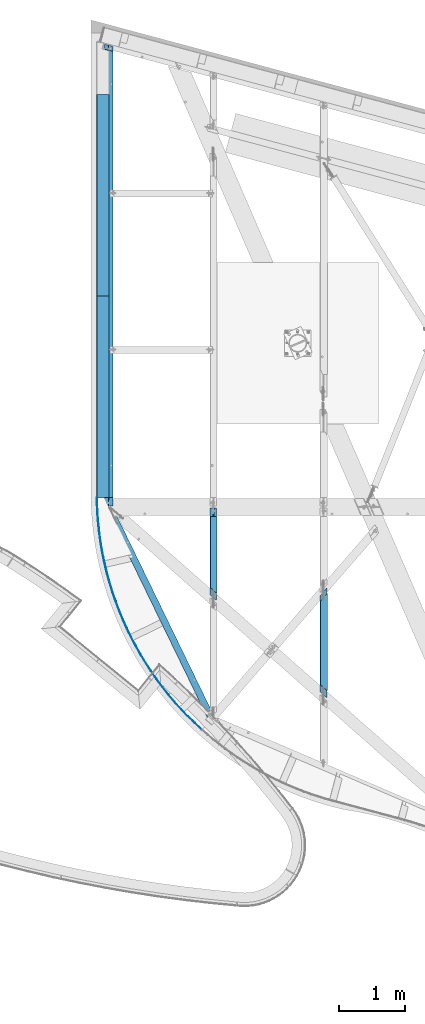
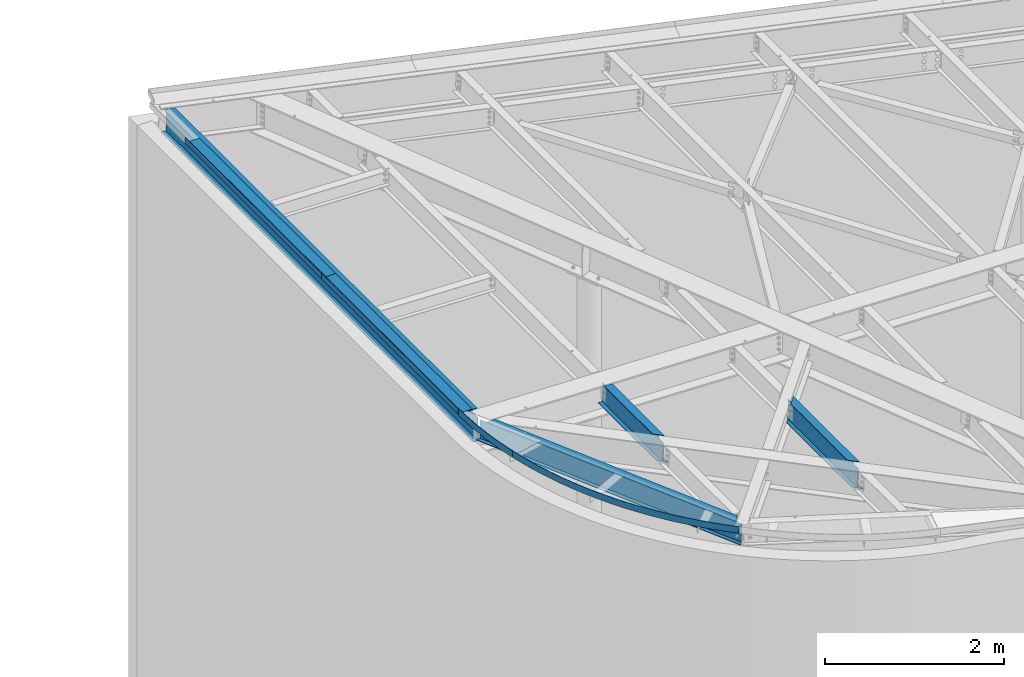
# One storey, part 1153 of 1763: 8 beams, 4 elements without a shape of their own.
"""IFC2X3 building model written with IfcOpenShell, lengths in millimetres."""

from ifc_helpers import new_model, si_unit, frame, origin_with_axes, place, context, subcontext, project, spatial, faceted_brep, material, type_object, element, aggregate, save


model = new_model("IFC2X3")

# Units and contexts
model_context = context("Model", 3, precision=1e-05, world=origin_with_axes())
body_context = subcontext(model_context, "Body", "Model", "MODEL_VIEW")
ifc_project = project(units=[si_unit("LENGTHUNIT", "METRE", prefix="MILLI"), si_unit("AREAUNIT", "SQUARE_METRE"), si_unit("VOLUMEUNIT", "CUBIC_METRE"), si_unit("MASSUNIT", "GRAM", prefix="KILO"), si_unit("TIMEUNIT", "SECOND"), si_unit("PLANEANGLEUNIT", "RADIAN"), si_unit("SOLIDANGLEUNIT", "STERADIAN"), si_unit("THERMODYNAMICTEMPERATUREUNIT", "DEGREE_CELSIUS"), si_unit("LUMINOUSINTENSITYUNIT", "LUMEN")], contexts=[model_context])

# Site, building, storey
site_placement = place(None, origin_with_axes())
site = spatial("IfcSite", under=ifc_project, at=site_placement, CompositionType="ELEMENT")
building_placement = place(site_placement, origin_with_axes())
building = spatial("IfcBuilding", under=site, at=building_placement, Name="Undefined", CompositionType="ELEMENT")
storey_placement = place(building_placement, origin_with_axes())
storey = spatial("IfcBuildingStorey", under=building, at=storey_placement, Name="Undefined", CompositionType="ELEMENT", Elevation=0.0)

# Assembly, beams
assembly_1_placement = place(storey_placement, origin_with_axes())
assembly_1 = element("IfcElementAssembly", 1, at=assembly_1_placement, inside=storey, Name="BEAM", AssemblyPlace="NOTDEFINED", PredefinedType="RIGID_FRAME")
ifc_material_1 = material(Name="STEEL/A36")
beam_type_1 = type_object("IfcBeamType", PredefinedType="NOTDEFINED")
beam_1_placement = place(assembly_1_placement, frame((-49591.1354609503, 64870.8062499989, 12741.275), z_axis=(0.0, -1.0, 0.0), x_axis=(-1.0, 0.0, 0.0)))
beam_1 = element("IfcBeam", 2, at=beam_1_placement, type_object=beam_type_1, material=ifc_material_1, Name="BENT_PLATE", context=body_context, shape_type="Brep", body=[
    faceted_brep([(0.0, -3.17499999999927, -1523.99999999999), (0.0, -3.17499999999927, 1524.0), (0.0, 3.17499999999927, 1524.0), (0.0, 3.17499999999927, -1523.99999999999), (184.149993896484, 3.17499999999927, 1524.0), (184.149993896484, 3.17499999999927, -1523.99999999999), (177.799993896479, -3.17499999999927, -1523.99999999999), (177.799993896479, -3.17499999999927, 1524.0), (184.149993896484, -73.0249969482429, 1524.0), (184.149993896484, -73.0249969482429, -1523.99999999999), (177.799993896479, -73.0249969482429, 1524.0), (177.799993896479, -73.0249969482429, -1523.99999999999)], [[[0, 1, 2, 3]], [[3, 2, 4, 5]], [[1, 0, 6, 7]], [[5, 4, 8, 9]], [[4, 2, 1, 7, 10, 8]], [[7, 6, 11, 10]], [[6, 0, 3, 5, 9, 11]], [[10, 11, 9, 8]]]),
])
beam_2_placement = place(assembly_1_placement, frame((-49591.1354609503, 67918.8062499989, 12741.275), z_axis=(0.0, -1.0, 0.0), x_axis=(-1.0, 0.0, 0.0)))
beam_2 = element("IfcBeam", 3, at=beam_2_placement, type_object=beam_type_1, material=ifc_material_1, Name="BENT_PLATE", context=body_context, shape_type="Brep", body=[
    faceted_brep([(0.0, -3.17499999999927, -1523.99999999999), (0.0, -3.17499999999927, 1524.0), (0.0, 3.17499999999927, 1524.0), (0.0, 3.17499999999927, -1523.99999999999), (184.149993896484, 3.17499999999927, 1524.0), (184.149993896484, 3.17499999999927, -1523.99999999999), (177.799993896479, -3.17499999999927, -1523.99999999999), (177.799993896479, -3.17499999999927, 1524.0), (184.149993896484, -73.0249969482429, 1524.0), (184.149993896484, -73.0249969482429, -1523.99999999999), (177.799993896479, -73.0249969482429, 1524.0), (177.799993896479, -73.0249969482429, -1523.99999999999)], [[[0, 1, 2, 3]], [[3, 2, 4, 5]], [[1, 0, 6, 7]], [[5, 4, 8, 9]], [[4, 2, 1, 7, 10, 8]], [[7, 6, 11, 10]], [[6, 0, 3, 5, 9, 11]], [[10, 11, 9, 8]]]),
])

assembly_2_placement = place(storey_placement, origin_with_axes())
assembly_2 = element("IfcElementAssembly", 4, at=assembly_2_placement, inside=storey, Name="BEAM", AssemblyPlace="NOTDEFINED", PredefinedType="RIGID_FRAME")
beam_type_2 = type_object("IfcBeamType", PredefinedType="NOTDEFINED")
beam_3_placement = place(assembly_2_placement, frame((-49650.8171570623, 62338.1625967416, 12762.537573956), z_axis=(0.00108272801955172, -0.00914849716521712, 0.999957565449481), x_axis=(-0.117525099963492, 0.993027181691531, 0.00921234499713815)))
beam_3 = element("IfcBeam", 5, at=beam_3_placement, type_object=beam_type_2, material=ifc_material_1, Name="PLATE", context=body_context, shape_type="Brep", body=[
    faceted_brep([(-0.333695476205321, 3.15741545087076, -44.4499999999898), (-0.33369547604525, 3.157415450798, 44.4499999999844), (50.144475592213, 8.22368790923792, 44.4500000000044), (50.144475592082, 8.22368790933251, -44.4499999999698), (0.333695476190769, -3.15741545087803, 44.449999999988), (0.33369547604525, -3.157415450798, -44.4499999999862), (50.7453385115368, 1.90217988102813, -44.4499999999643), (50.7453385116678, 1.9021798809481, 44.4500000000098), (100.673192931077, 12.7581774184728, 44.4500000000298), (100.673192930946, 12.7581774185601, -44.449999999948), (101.20746119984, 6.43069313042361, -44.4499999999425), (101.207461199971, 6.43069313034357, 44.4500000000317), (151.246854412151, 16.7603812387897, 44.4500000000517), (151.246854412006, 16.7603812388697, -44.4499999999261), (151.714468795893, 10.4276222202679, -44.4499999999189), (151.714468796039, 10.4276222201734, 44.4500000000571), (201.859852924026, 20.2298556450842, 44.4500000000753), (201.859852923895, 20.2298556451715, -44.4499999999025), (202.260761578305, 13.8925240102762, -44.4499999998952), (202.260761578436, 13.8925240102035, 44.4500000000789), (252.50657699407, 23.1662159760963, 44.4500000000971), (252.506576993939, 23.166215976169, -44.449999999877), (252.840735470032, 16.8250143461482, -44.4499999998734), (252.840735470163, 16.8250143460682, 44.4500000001044), (303.181411410435, 25.5691366769752, 44.4500000001226), (303.181411410289, 25.5691366770552, -44.4499999998552), (303.448782659863, 19.2247681021254, -44.4499999998498), (303.448782659994, 19.2247681020381, 44.4500000001262), (353.878737844672, 27.4383513354842, 44.4500000001462), (353.878737844527, 27.4383513355642, -44.4499999998297), (354.07929222408, 21.0915192170432, -44.4499999998261), (354.079292224225, 21.0915192169632, 44.4500000001517), (404.592935474662, 28.7736527114175, 44.4500000001699), (404.592935474517, 28.7736527114903, -44.4499999998043), (404.726650748547, 22.4250607238719, -44.4499999998006), (404.726650748693, 22.4250607237918, 44.4500000001735), (455.31838160778, 29.5748927596578, 44.4500000001954), (455.318381607634, 29.5748927597378, -44.4499999997788), (455.385242951117, 23.2252447726059, -44.4499999997752), (455.385242951263, 23.2252447725259, 44.450000000199), (506.049452304258, 29.8419826465906, 44.4500000002208), (506.049452304112, 29.8419826466707, -44.4499999997552), (506.049452304112, 23.4919826466794, -44.4499999997497), (506.049452304243, 23.4919826465994, 44.4500000002245), (556.780523000736, 29.5748927598906, 44.4500000002463), (556.780523000605, 29.5748927599707, -44.4499999997297), (556.713661657093, 23.2252447728315, -44.4499999997261), (556.713661657224, 23.2252447727515, 44.4500000002517), (607.505969133854, 28.7736527118759, 44.4500000002718), (607.505969133708, 28.7736527119559, -44.4499999997024), (607.372253859648, 22.4250607243303, -44.4499999996988), (607.372253859794, 22.4250607242502, 44.4500000002754), (658.220166763829, 27.4383513361827, 44.450000000299), (658.220166763698, 27.4383513362627, -44.4499999996769), (658.019612384116, 21.0915192177345, -44.4499999996715), (658.019612384262, 21.0915192176617, 44.4500000003027), (708.917493198082, 25.5691366779065, 44.4500000003263), (708.917493197936, 25.5691366779938, -44.4499999996515), (708.650121948333, 19.2247681030494, -44.4499999996442), (708.650121948478, 19.2247681029621, 44.45000000033), (759.592327614431, 23.1662159772604, 44.4500000003536), (759.592327614286, 23.1662159773405, -44.4499999996242), (759.258169138149, 16.8250143473124, -44.4499999996169), (759.258169138295, 16.8250143472324, 44.4500000003572), (810.239051684446, 20.2298556464884, 44.4500000003827), (810.239051684301, 20.2298556465685, -44.4499999995951), (809.838143029861, 13.8925240116732, -44.4499999995915), (809.838143030007, 13.8925240115932, 44.4500000003845), (860.852050196321, 16.7603812404195, 44.4500000004082), (860.852050196176, 16.7603812405068, -44.449999999566), (860.384435812244, 10.4276222218905, -44.4499999995624), (860.38443581239, 10.4276222218032, 44.4500000004136), (911.425711677352, 12.7581774203427, 44.4500000004373), (911.425711677221, 12.7581774204154, -44.4499999995369), (910.891443408298, 6.43069313228625, -44.4499999995332), (910.891443408444, 6.43069313219166, 44.4500000004427), (961.954429016201, 8.22368791134068, 44.4500000004682), (961.95442901607, 8.22368791141344, -44.4499999995096), (961.353566096572, 1.90217988312361, -44.4499999995041), (961.353566096703, 1.90217988304357, 44.45000000047), (1012.43260008444, 3.15741545311903, 44.4500000004955), (1012.43260008431, 3.15741545319906, -44.4499999994805), (1011.76520913218, -3.15741544854973, 44.4500000004991), (1011.76520913203, -3.15741544847697, -44.4499999994769)], [[[0, 1, 2, 3]], [[4, 5, 6, 7]], [[5, 4, 1, 0]], [[3, 2, 8, 9]], [[7, 6, 10, 11]], [[9, 8, 12, 13]], [[11, 10, 14, 15]], [[13, 12, 16, 17]], [[15, 14, 18, 19]], [[17, 16, 20, 21]], [[19, 18, 22, 23]], [[21, 20, 24, 25]], [[23, 22, 26, 27]], [[25, 24, 28, 29]], [[27, 26, 30, 31]], [[29, 28, 32, 33]], [[31, 30, 34, 35]], [[33, 32, 36, 37]], [[35, 34, 38, 39]], [[37, 36, 40, 41]], [[39, 38, 42, 43]], [[41, 40, 44, 45]], [[43, 42, 46, 47]], [[45, 44, 48, 49]], [[47, 46, 50, 51]], [[49, 48, 52, 53]], [[51, 50, 54, 55]], [[53, 52, 56, 57]], [[55, 54, 58, 59]], [[57, 56, 60, 61]], [[59, 58, 62, 63]], [[61, 60, 64, 65]], [[63, 62, 66, 67]], [[65, 64, 68, 69]], [[67, 66, 70, 71]], [[69, 68, 72, 73]], [[71, 70, 74, 75]], [[73, 72, 76, 77]], [[75, 74, 78, 79]], [[77, 76, 80, 81]], [[76, 72, 68, 64, 60, 56, 52, 48, 44, 40, 36, 32, 28, 24, 20, 16, 12, 8, 2, 1, 4, 7, 11, 15, 19, 23, 27, 31, 35, 39, 43, 47, 51, 55, 59, 63, 67, 71, 75, 79, 82, 80]], [[79, 78, 83, 82]], [[78, 74, 70, 66, 62, 58, 54, 50, 46, 42, 38, 34, 30, 26, 22, 18, 14, 10, 6, 5, 0, 3, 9, 13, 17, 21, 25, 29, 33, 37, 41, 45, 49, 53, 57, 61, 65, 69, 73, 77, 81, 83]], [[82, 83, 81, 80]]]),
])
beam_4_placement = place(assembly_2_placement, frame((-48181.49405106, 59831.6606347335, 12734.4806239333), z_axis=(0.00488589028494607, -0.00833597648616706, 0.999953318696501), x_axis=(-0.50564065819503, 0.862690074332748, 0.00966232000372705)))
beam_4 = element("IfcBeam", 6, at=beam_4_placement, type_object=beam_type_2, material=ifc_material_1, Name="PLATE", context=body_context, shape_type="Brep", body=[
    faceted_brep([(-0.957979800179601, 3.02702819671686, -44.4499999999971), (-0.957979800092289, 3.0270281963185, 44.4500000000025), (140.495201600686, 45.4198935538607, 44.4500000001062), (140.495201600599, 45.4198935542554, -44.4499999998934), (0.957979800165049, -3.02702819672595, 44.4499999999989), (0.957979800092289, -3.02702819632759, -44.4500000000007), (142.224732063449, 39.3099652094934, -44.449999999897), (142.224732063551, 39.3099652091023, 44.4500000001026), (283.18109317885, 83.4579522078766, 44.4500000002081), (283.181093178748, 83.4579522082731, -44.4499999997915), (284.722569845835, 77.2978913575298, -44.4499999997934), (284.722569845937, 77.2978913571387, 44.4500000002045), (426.965660967966, 117.105472581708, 44.4500000003063), (426.965660967893, 117.105472582096, -44.4499999996915), (428.317635831772, 110.901065763755, -44.4499999996951), (428.317635831845, 110.901065763361, 44.4500000003045), (571.713838944983, 146.33084741154, 44.4500000004064), (571.713838944896, 146.330847411931, -44.4499999995933), (572.875042009284, 140.08792282138, -44.4499999995969), (572.875042009371, 140.08792282098, 44.4500000004009), (717.289655906206, 171.10662343719, 44.4500000005009), (717.289655906134, 171.106623437578, -44.4499999994987), (718.258996378849, 164.831045452398, -44.4499999995023), (718.258996378951, 164.831045452003, 44.4500000004955), (863.556363193886, 191.409527190643, 44.4500000005937), (863.556363193813, 191.409527191037, -44.4499999994059), (864.332930511475, 185.107190862242, -44.4499999994077), (864.332930511562, 185.107190861852, 44.4500000005901), (1010.37656315282, 207.220486858378, 44.4500000006847), (1010.37656315273, 207.220486858765, -44.4499999993131), (1010.95962783611, 200.897312373187, -44.4499999993168), (1010.9596278362, 200.897312372794, 44.4500000006828), (1157.61233819685, 218.524650196663, 44.4500000007756), (1157.61233819675, 218.524650197052, -44.449999999224), (1158.00135253595, 212.186577316126, -44.4499999992277), (1158.00135253603, 212.186577315733, 44.450000000772), (1305.12538036356, 225.311398483269, 44.4500000008593), (1305.12538036348, 225.311398483665, -44.4499999991385), (1305.31997893249, 218.964380963833, -44.4499999991422), (1305.31997893259, 218.964380963445, 44.4500000008575), (1452.77712123591, 227.574356492305, 44.4500000009448), (1452.77712123581, 227.5743564927, -44.4499999990549), (1452.77712123579, 221.22435649269, -44.4499999990585), (1452.77712123588, 221.224356492296, 44.4500000009411), (1600.42886210822, 225.31139848284, 44.4500000010266), (1600.42886210814, 225.311398483234, -44.449999998973), (1600.23426353908, 218.964380963405, -44.4499999989766), (1600.23426353915, 218.964380963005, 44.450000001023), (1747.94190427489, 218.524650195801, 44.4500000011067), (1747.9419042748, 218.524650196196, -44.449999998893), (1747.55288993554, 212.186577315262, -44.4499999988966), (1747.55288993564, 212.186577314867, 44.4500000010994), (1895.17767931882, 207.220486857084, 44.4500000011794), (1895.17767931873, 207.220486857475, -44.4499999988184), (1894.59461463529, 200.897312371897, -44.449999998822), (1894.59461463538, 200.897312371502, 44.4500000011776), (2041.99787927762, 191.409527188918, 44.450000001254), (2041.99787927752, 191.409527189311, -44.4499999987456), (2041.22131195979, 185.107190860526, -44.4499999987493), (2041.22131195989, 185.107190860132, 44.4500000012504), (2188.26458656511, 171.106623435033, 44.450000001325), (2188.26458656503, 171.106623435431, -44.4499999986729), (2187.29524609225, 164.831045450253, -44.4499999986783), (2187.29524609233, 164.831045449853, 44.4500000013213), (2333.84040352613, 146.330847408963, 44.4500000013904), (2333.84040352605, 146.330847409357, -44.4499999986056), (2332.67920046161, 140.087922818802, -44.449999998611), (2332.6792004617, 140.087922818411, 44.4500000013886), (2478.5885815029, 117.105472578705, 44.4500000014577), (2478.58858150282, 117.1054725791, -44.4499999985419), (2477.23660663888, 110.901065760756, -44.4499999985474), (2477.23660663895, 110.901065760369, 44.4500000014523), (2622.37314929174, 83.4579522044642, 44.4500000015178), (2622.37314929166, 83.4579522048589, -44.4499999984819), (2620.83167262452, 77.2978913541119, -44.4499999984873), (2620.8316726246, 77.297891353719, 44.4500000015123), (2765.05904086957, 45.4198935500208, 44.450000001576), (2765.05904086948, 45.4198935504191, -44.4499999984218), (2763.32951040656, 39.309965205668, -44.4499999984273), (2763.32951040666, 39.3099652052697, 44.4500000015723), (2906.51222226999, 3.02702819206934, 44.4500000016324), (2906.51222226988, 3.02702819246588, -44.4499999983673), (2904.59626266967, -3.02702820097147, 44.4500000016269), (2904.59626266958, -3.02702820057129, -44.4499999983709)], [[[0, 1, 2, 3]], [[4, 5, 6, 7]], [[5, 4, 1, 0]], [[3, 2, 8, 9]], [[7, 6, 10, 11]], [[9, 8, 12, 13]], [[11, 10, 14, 15]], [[13, 12, 16, 17]], [[15, 14, 18, 19]], [[17, 16, 20, 21]], [[19, 18, 22, 23]], [[21, 20, 24, 25]], [[23, 22, 26, 27]], [[25, 24, 28, 29]], [[27, 26, 30, 31]], [[29, 28, 32, 33]], [[31, 30, 34, 35]], [[33, 32, 36, 37]], [[35, 34, 38, 39]], [[37, 36, 40, 41]], [[39, 38, 42, 43]], [[41, 40, 44, 45]], [[43, 42, 46, 47]], [[45, 44, 48, 49]], [[47, 46, 50, 51]], [[49, 48, 52, 53]], [[51, 50, 54, 55]], [[53, 52, 56, 57]], [[55, 54, 58, 59]], [[57, 56, 60, 61]], [[59, 58, 62, 63]], [[61, 60, 64, 65]], [[63, 62, 66, 67]], [[65, 64, 68, 69]], [[67, 66, 70, 71]], [[69, 68, 72, 73]], [[71, 70, 74, 75]], [[73, 72, 76, 77]], [[75, 74, 78, 79]], [[77, 76, 80, 81]], [[76, 72, 68, 64, 60, 56, 52, 48, 44, 40, 36, 32, 28, 24, 20, 16, 12, 8, 2, 1, 4, 7, 11, 15, 19, 23, 27, 31, 35, 39, 43, 47, 51, 55, 59, 63, 67, 71, 75, 79, 82, 80]], [[79, 78, 83, 82]], [[78, 74, 70, 66, 62, 58, 54, 50, 46, 42, 38, 34, 30, 26, 22, 18, 14, 10, 6, 5, 0, 3, 9, 13, 17, 21, 25, 29, 33, 37, 41, 45, 49, 53, 57, 61, 65, 69, 73, 77, 81, 83]], [[82, 83, 81, 80]]]),
])

# Beam
ifc_material_2 = material(Name="STEEL/A992")
beam_type_3 = type_object("IfcBeamType", Name="W14X22", PredefinedType="NOTDEFINED")
beam_5_placement = place(assembly_1_placement, frame((-49591.1354609503, 63201.5499999989, 12563.475), z_axis=(0.0, 0.0, 1.0), x_axis=(0.0, 1.0, 0.0)))
beam_5 = element("IfcBeam", 7, at=beam_5_placement, type_object=beam_type_3, material=ifc_material_2, Name="BEAM", ObjectType="W14X22", context=body_context, shape_type="Brep", body=[
    faceted_brep([(132.556250190733, -3.17500000000291, 136.265001679338), (132.556250190733, 3.17500000000291, 136.265001679338), (18.2562499999622, 3.17500000000291, 136.265001679338), (18.2562499999622, -3.17500000000291, 136.265001679338), (137.41632970878, -3.17500000000291, 137.231731601925), (137.41632970878, 3.17500000000291, 137.231731601925), (141.536506176933, -3.17500000000291, 139.984745502403), (141.536506176933, 3.17500000000291, 139.984745502403), (144.289520077407, -3.17500000000291, 144.104921970556), (144.289520077407, 3.17500000000291, 144.104921970556), (145.256249999999, -3.17500000000291, 148.965001488603), (145.256249999999, 3.17500000000291, 148.965001488603), (145.256249999999, -63.5, 174.625), (145.256249999999, 63.5, 174.625), (145.256249999999, 63.5, 166.6875), (145.256249999999, 3.17500000000291, 166.6875), (145.256249999999, -3.17500000000291, 166.6875), (145.256249999999, -63.5, 166.6875), (18.2562499999622, -3.17500000000291, -166.6875), (18.2562499999622, -63.5, -166.6875), (6964.61690272956, -63.5, -166.6875), (6980.78093782385, -3.17500000000291, -166.6875), (18.2562499999622, -63.5, -174.625), (6964.61690272956, -63.5, -174.625), (18.2562499999622, 63.5, -174.625), (6998.6464502965, 63.5, -174.625), (18.2562499999622, 63.5, -166.6875), (6998.6464502965, 63.5, -166.6875), (18.2562499999622, 3.17500000000291, -166.6875), (6982.48241520221, 3.17500000000291, -166.6875), (6982.48241520221, 3.17500000000291, 145.869959427067), (6980.78093782385, -3.17500000000291, 145.869959427067), (6920.85112686776, 3.17500000000291, 145.869959427073), (6919.14964948945, -3.17500000000291, 145.869959427073), (6915.81960230653, 3.17500000000291, 146.83668934966), (6914.11812492822, -3.17500000000291, 146.83668934966), (6911.55408174887, 3.17500000000291, 149.589703250138), (6909.85260437056, -3.17500000000291, 149.589703250138), (6908.70395203264, 3.17500000000291, 153.709879718292), (6907.00247465431, -3.17500000000291, 153.709879718292), (6907.70311957063, 3.17500000000291, 158.569959236338), (6906.00164219231, -3.17500000000291, 158.569959236338), (6923.86715466547, 63.5, 174.625), (6889.83760709828, -63.5, 174.625), (6889.83760709828, -63.5, 166.6875), (6906.00164219269, -3.17500000000291, 166.6875), (6907.70311957105, 3.17500000000291, 166.6875), (6923.86715466547, 63.5, 166.6875)], [[[0, 1, 2, 3]], [[4, 5, 1, 0]], [[6, 7, 5, 4]], [[8, 9, 7, 6]], [[10, 11, 9, 8]], [[12, 13, 14, 15, 11, 10, 16, 17]], [[18, 19, 20, 21]], [[19, 22, 23, 20]], [[22, 24, 25, 23]], [[24, 26, 27, 25]], [[26, 28, 29, 27]], [[21, 20, 23, 25, 27, 29, 30, 31]], [[30, 32, 33, 31]], [[34, 35, 33, 32]], [[36, 37, 35, 34]], [[38, 39, 37, 36]], [[40, 41, 39, 38]], [[42, 43, 44, 45, 41, 40, 46, 47]], [[44, 43, 12, 17]], [[45, 44, 17, 16]], [[8, 6, 4, 0, 3, 18, 21, 31, 33, 35, 37, 39, 41, 45, 16, 10]], [[28, 26, 24, 22, 19, 18, 3, 2]], [[46, 40, 38, 36, 34, 32, 30, 29, 28, 2, 1, 5, 7, 9, 11, 15]], [[47, 46, 15, 14]], [[42, 47, 14, 13]], [[43, 42, 13, 12]]]),
])

aggregate(assembly_1, [beam_1, beam_2, beam_5])

# Assembly, beam
assembly_3_placement = place(storey_placement, origin_with_axes())
assembly_3 = element("IfcElementAssembly", 8, at=assembly_3_placement, inside=storey, Name="BEAM", AssemblyPlace="NOTDEFINED", PredefinedType="RIGID_FRAME")
beam_type_4 = type_object("IfcBeamType", Name="W12X16", PredefinedType="NOTDEFINED")
beam_6_placement = place(assembly_3_placement, frame((-46340.5472371989, 60331.0304366691, 12489.8609543434), z_axis=(0.0294363099980619, 0.0, 0.999566657934176), x_axis=(0.0, 1.0, 0.0)))
beam_6 = element("IfcBeam", 9, at=beam_6_placement, type_object=beam_type_4, material=ifc_material_2, Name="BEAM", ObjectType="W12X16", context=body_context, shape_type="Brep", body=[
    faceted_brep([(27.1730545144965, -3.17500000023574, -146.050000000021), (-14.8073242350511, -50.8000000002357, -146.050000000032), (1645.62213272548, -50.8000000002357, -146.050000000032), (1590.87677431411, -3.17500000023574, -146.050000000021), (-14.6424864781366, -50.8000000002576, -152.400000000032), (1645.40717272284, -50.8000000002576, -152.400000000032), (74.9156548542305, 50.7999999997774, -152.400000000003), (1528.61707477858, 50.7999999997774, -152.400000000003), (74.750817097316, 50.7999999997846, -146.050000000005), (1528.83203478122, 50.7999999997846, -146.050000000005), (32.7704383477685, 3.17499999977008, -146.050000000016), (1583.57739319259, 3.17499999977008, -146.050000000016), (1592.44731991178, 3.17500000017026, 115.970999139781), (1599.74670103329, -3.17499999982829, 115.970999139805), (1522.24746324701, 3.17500000017026, 115.970999129389), (1529.54684436989, -3.17499999982829, 115.970999129382), (1514.84262438725, 3.17500000017026, 116.937729050809), (1522.14200551013, -3.17499999982829, 116.937729050798), (1508.56510511816, 3.17500000017753, 119.69074295029), (1515.86448624104, -3.17499999982101, 119.690742950281), (1504.37060084258, 3.17500000018481, 123.810919417774), (1511.66998196547, -3.17499999981374, 123.810919417767), (1502.89768681321, 3.17500000019209, 128.670998935582), (1510.1970679361, -3.17499999981374, 128.670998935573), (1564.94242634942, -50.7999999997774, 152.400000000001), (1564.94242635177, -50.7999999997919, 146.050000000003), (1510.1970679303, -3.17499999978463, 146.050000000014), (1502.89768680744, 3.17500000022119, 146.050000000017), (1448.15232838597, 50.8000000002285, 146.05000000003), (1448.15232838362, 50.800000000243, 152.400000000031), (90.8485894317782, -50.7999999997919, 146.050000000003), (132.828968223388, -3.17499999978463, 146.050000000014), (128.51278903224, -3.17499999982101, 116.75468887553), (122.980501869599, -3.17499999982829, 113.937620590901), (116.425749382193, -3.17499999983556, 112.947094292258), (20.4498261576373, -3.17499999982829, 112.947094269524), (133.352183426308, -3.17499999981374, 125.894358175809), (132.15963827174, -3.17499999981374, 120.958869184187), (26.0472099909093, 3.17500000017753, 112.947094269519), (122.023133221104, 3.17500000017753, 112.947094292274), (128.577885708517, 3.17500000017026, 113.937620590921), (134.110172871158, 3.17500000017753, 116.754688875548), (137.757022110658, 3.17500000018481, 120.958869184205), (138.949567265227, 3.17500000019209, 125.894358175825), (138.426352062263, 3.17500000022119, 146.050000000017), (180.406730853872, 50.8000000002285, 146.05000000003), (180.241892811471, 50.800000000243, 152.400000000031), (90.6837513893697, -50.7999999997774, 152.400000000001)], [[[0, 1, 2, 3]], [[1, 4, 5, 2]], [[4, 6, 7, 5]], [[6, 8, 9, 7]], [[8, 10, 11, 9]], [[3, 2, 5, 7, 9, 11, 12, 13]], [[13, 12, 14, 15]], [[15, 14, 16, 17]], [[17, 16, 18, 19]], [[19, 18, 20, 21]], [[21, 20, 22, 23]], [[24, 25, 26, 23, 22, 27, 28, 29]], [[26, 25, 30, 31]], [[32, 33, 34, 35, 0, 3, 13, 15, 17, 19, 21, 23, 26, 31, 36, 37]], [[10, 8, 6, 4, 1, 0, 35, 38]], [[27, 22, 20, 18, 16, 14, 12, 11, 10, 38, 39, 40, 41, 42, 43, 44]], [[28, 27, 44, 45]], [[29, 28, 45, 46]], [[24, 29, 46, 47]], [[25, 24, 47, 30]], [[46, 45, 44, 43, 36, 31, 30, 47]], [[42, 37, 36, 43]], [[41, 32, 37, 42]], [[40, 33, 32, 41]], [[39, 34, 33, 40]], [[38, 35, 34, 39]]]),
])
aggregate(assembly_3, [beam_6])

assembly_4_placement = place(storey_placement, origin_with_axes())
assembly_4 = element("IfcElementAssembly", 10, at=assembly_4_placement, inside=storey, Name="BEAM", AssemblyPlace="NOTDEFINED", PredefinedType="RIGID_FRAME")
beam_type_5 = type_object("IfcBeamType", Name="W12X14", PredefinedType="NOTDEFINED")
beam_7_placement = place(assembly_4_placement, frame((-48006.3414809649, 61800.0688176109, 12540.5279768686), z_axis=(0.0294363099980619, 0.0, 0.999566657934176), x_axis=(0.0, 1.0, 0.0)))
beam_7 = element("IfcBeam", 11, at=beam_7_placement, type_object=beam_type_5, material=ifc_material_2, Name="BEAM", ObjectType="W12X14", context=body_context, shape_type="Brep", body=[
    faceted_brep([(27.7903100109761, -2.38125000023138, -144.46250000002), (-14.8897417177359, -50.800000000243, -144.462500000032), (1383.22493238797, -50.800000000243, -144.462500000032), (1383.22493238797, -2.38125000023138, -144.46250000002), (-14.7249039608214, -50.8000000002503, -150.812500000033), (1383.22493238797, -50.8000000002503, -150.812500000033), (74.8332373715457, 50.7999999997628, -150.812500000004), (1383.22493238797, 50.7999999997628, -150.812500000004), (74.6683996146385, 50.7999999997774, -144.462500000003), (1383.22493238797, 50.7999999997774, -144.462500000003), (31.9883478859265, 2.38124999976571, -144.462500000018), (1383.22493238797, 2.38124999976571, -144.462500000018), (1383.22493238797, 2.38125000015862, 106.386048611537), (1383.22493238797, -2.38124999985303, 106.386048611546), (1271.30618830073, 2.38125000015862, 106.386048611766), (1271.30618830073, -2.38124999985303, 106.386048611757), (1266.44610878269, 2.38125000015862, 107.352778534354), (1266.44610878269, -2.38124999984575, 107.352778534345), (1262.32593231453, 2.38125000015862, 110.105792434835), (1262.32593231453, -2.38124999983847, 110.105792434822), (1259.57291841406, 2.38125000017317, 114.225968902991), (1259.57291841406, -2.38124999983847, 114.225968902978), (1258.60618849147, 2.38125000017317, 119.086048421037), (1258.60618849147, -2.3812499998312, 119.086048421024), (1258.60618849147, -50.7999999997919, 150.812500000002), (1258.60618849147, -50.7999999997992, 144.462500000001), (1258.60618849147, -2.38124999978754, 144.462500000016), (1258.60618849147, 2.38125000020955, 144.462500000016), (1258.60618849147, 50.8000000002212, 144.462500000031), (1258.60618849147, 50.8000000002285, 150.812500000031), (90.8485913792683, -50.7999999997992, 144.462500000001), (133.528643150741, -2.38124999978754, 144.462500000016), (129.213633971951, -2.3812499998312, 115.122101716412), (123.68134683348, -2.38124999983847, 112.305033471235), (117.126594392663, -2.3812499998312, 111.314507187268), (21.1506709352834, -2.3812499998312, 111.31450716453), (134.053028440721, -2.38124999982392, 124.26177091922), (132.860483226257, -2.38124999982392, 119.32628197351), (25.3487088102411, 2.38125000015862, 111.314507164527), (121.324632271848, 2.38125000015862, 111.31450718728), (127.879384712673, 2.38125000016589, 112.30503347125), (133.411671851136, 2.38125000016589, 115.122101716426), (137.058521105442, 2.38125000017317, 119.326281973523), (138.251066319906, 2.38125000018772, 124.261770919233), (137.726681029897, 2.38125000020955, 144.462500000016), (180.40673280137, 50.8000000002212, 144.462500000031), (180.241894860061, 50.8000000002285, 150.812500000031), (90.6837534379665, -50.7999999997919, 150.812500000002)], [[[0, 1, 2, 3]], [[1, 4, 5, 2]], [[4, 6, 7, 5]], [[6, 8, 9, 7]], [[8, 10, 11, 9]], [[3, 2, 5, 7, 9, 11, 12, 13]], [[13, 12, 14, 15]], [[15, 14, 16, 17]], [[17, 16, 18, 19]], [[19, 18, 20, 21]], [[21, 20, 22, 23]], [[24, 25, 26, 23, 22, 27, 28, 29]], [[26, 25, 30, 31]], [[32, 33, 34, 35, 0, 3, 13, 15, 17, 19, 21, 23, 26, 31, 36, 37]], [[10, 8, 6, 4, 1, 0, 35, 38]], [[27, 22, 20, 18, 16, 14, 12, 11, 10, 38, 39, 40, 41, 42, 43, 44]], [[28, 27, 44, 45]], [[29, 28, 45, 46]], [[24, 29, 46, 47]], [[25, 24, 47, 30]], [[46, 45, 44, 43, 36, 31, 30, 47]], [[42, 37, 36, 43]], [[41, 32, 37, 42]], [[40, 33, 32, 41]], [[39, 34, 33, 40]], [[38, 35, 34, 39]]]),
])
aggregate(assembly_4, [beam_7])

# Beam
beam_8_placement = place(assembly_2_placement, frame((-48035.9381809574, 59999.4231021343, 12552.6585290006), z_axis=(0.00424874998391897, -0.00874810996689484, 0.999952708229535), x_axis=(-0.436855685846517, 0.89947903168398, 0.00972529199658307)))
beam_8 = element("IfcBeam", 12, at=beam_8_placement, type_object=beam_type_5, material=ifc_material_2, Name="BEAM", ObjectType="W12X14", context=body_context, shape_type="Brep", body=[
    faceted_brep([(3375.05900144335, -50.8000000049324, -144.462499999265), (3374.99724291851, -50.8000000049542, -150.812499999261), (3398.51419679551, -2.38125042095271, -150.812499999265), (3398.57595532035, -2.38125000505534, -144.462499999268), (3537.13525637134, -2.38125240910813, -144.462634433903), (3537.06231278856, -2.37581971266991, -150.812499999238), (-7.324891108874, 50.7999999994208, -150.812499999945), (-7.2631325841794, 50.7999999994463, -144.462499999949), (3562.9515303401, 50.799999994626, -144.462499999241), (3562.88977181508, 50.7999999946078, -150.81249999924), (13.3846913697198, 2.38124999950378, -144.462499999936), (3539.43457679579, 2.38124999474167, -144.462499999239), (15.8547301287326, 2.38125000032232, 109.506424925234), (67.7549222511007, 2.38125000024957, 109.50642491665), (73.009922931582, 2.38125000024957, 110.462314463606), (77.4738684471522, 2.38125000024957, 113.186089430443), (80.4747841640783, 2.38125000026412, 117.267729650162), (81.5609308680723, 2.38125000027139, 122.092810353892), (81.7784957016411, 2.38125000035143, 144.462499999954), (3403.69911137052, 2.38124999586216, 144.462500000611), (3403.44833836073, 2.38124999578577, 118.6778394542), (3404.48735475837, 2.38124999576394, 113.783747230375), (3407.53950964409, 2.38124999574575, 109.625849520651), (3412.13501766458, 2.38124999573483, 106.844126770911), (3417.56654172849, 2.38124999571664, 105.866739626266), (3541.86921689181, 2.38124999555657, 105.866739626783), (3539.55607392025, -2.38125000443324, 105.866739626679), (36.0016903025826, -50.800000000454, -150.81249999992), (36.0634488272626, -50.8000000004322, -144.462499999925), (15.415624873378, -2.38125000048967, -144.462499999936), (17.8856636323908, -2.38124999967113, 109.506424925323), (69.7858557533764, -2.38124999974389, 109.506424916708), (75.0408564338577, -2.38124999974389, 110.462314463666), (79.5048019494425, -2.38124999973661, 113.186089430501), (82.5057176663686, -2.38124999972933, 117.267729650224), (83.5918643703772, -2.38124999972206, 122.092810353952), (104.519012457982, -50.79999999957, 150.812499999964), (61.1924310767063, 50.8000000003085, 150.81249999994), (61.1306717621192, 50.8000000002794, 144.462499999941), (83.8094292038732, -2.38124999964566, 144.462499999956), (104.457253143395, -50.7999999995845, 144.462499999967), (3401.38596839868, -2.38125000412401, 144.462500000609), (3377.86901485166, -50.800000004001, 144.462500000614), (3377.93077283405, -50.8000000039829, 150.812500000609), (3427.27782289992, 50.799999995761, 150.812500000606), (3401.4477262765, -2.38125021941232, 150.812500000608), (3427.21606491753, 50.7999999957465, 144.462500000607), (3401.1351953889, -2.38125000420405, 118.677839454096), (3402.17421178654, -2.38125000422588, 113.783747230269), (3405.22636667227, -2.38125000423679, 109.625849520546), (3409.82187469275, -2.38125000425862, 106.844126770806), (3415.25339875666, -2.38125000426589, 105.866739626163)], [[[0, 1, 2, 3]], [[4, 3, 2, 5]], [[6, 7, 8, 9]], [[7, 10, 11, 8]], [[11, 10, 12, 13, 14, 15, 16, 17, 18, 19, 20, 21, 22, 23, 24, 25]], [[9, 8, 11, 25, 26, 4, 5]], [[1, 27, 6, 9, 5, 2]], [[28, 27, 1, 0]], [[29, 28, 0, 3]], [[10, 7, 6, 27, 28, 29, 30, 12]], [[31, 13, 12, 30]], [[32, 14, 13, 31]], [[33, 15, 14, 32]], [[34, 16, 15, 33]], [[35, 17, 16, 34]], [[36, 37, 38, 18, 17, 35, 39, 40]], [[40, 39, 41, 42]], [[36, 40, 42, 43]], [[44, 37, 36, 43, 45]], [[38, 37, 44, 46]], [[18, 38, 46, 19]], [[44, 45, 43, 42, 41, 47, 20, 19, 46]], [[20, 47, 48, 21]], [[21, 48, 49, 22]], [[22, 49, 50, 23]], [[23, 50, 51, 24]], [[25, 24, 51, 26]], [[50, 49, 48, 47, 41, 39, 35, 34, 33, 32, 31, 30, 29, 3, 4, 26, 51]]]),
])

aggregate(assembly_2, [beam_3, beam_4, beam_8])

save(model, "model.ifc")
